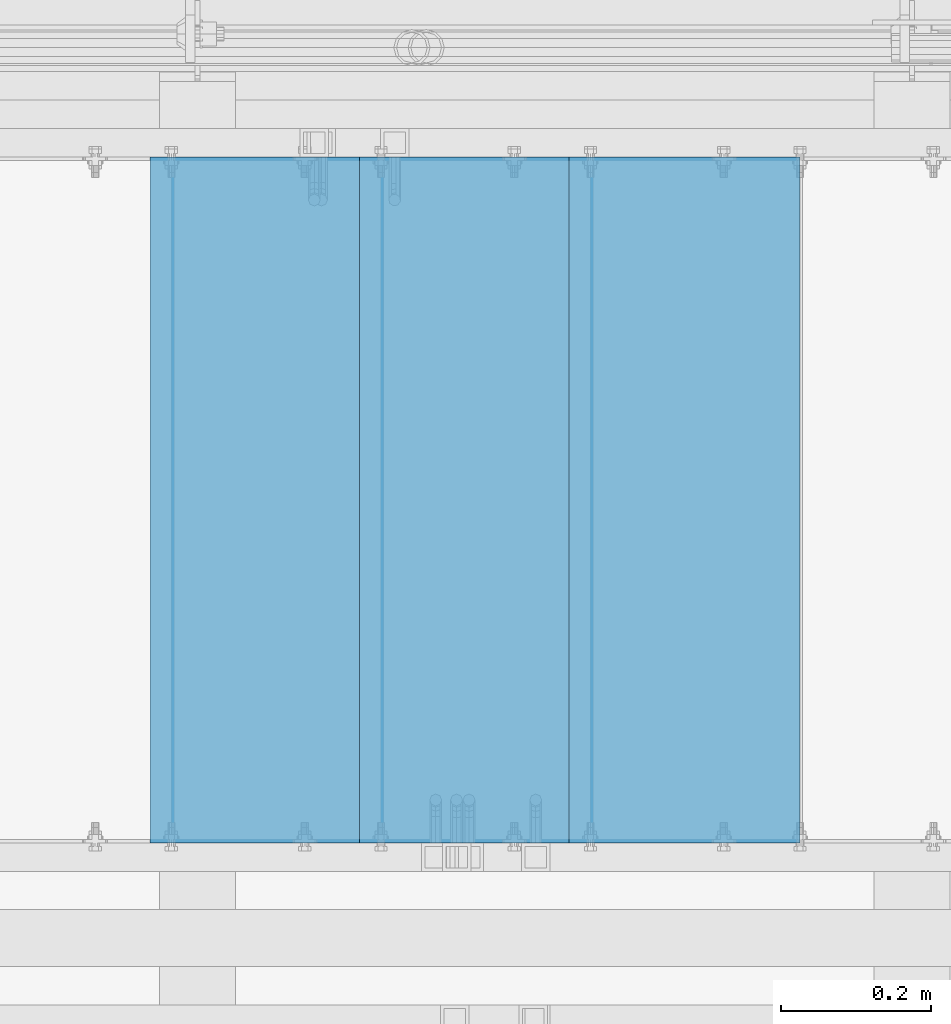
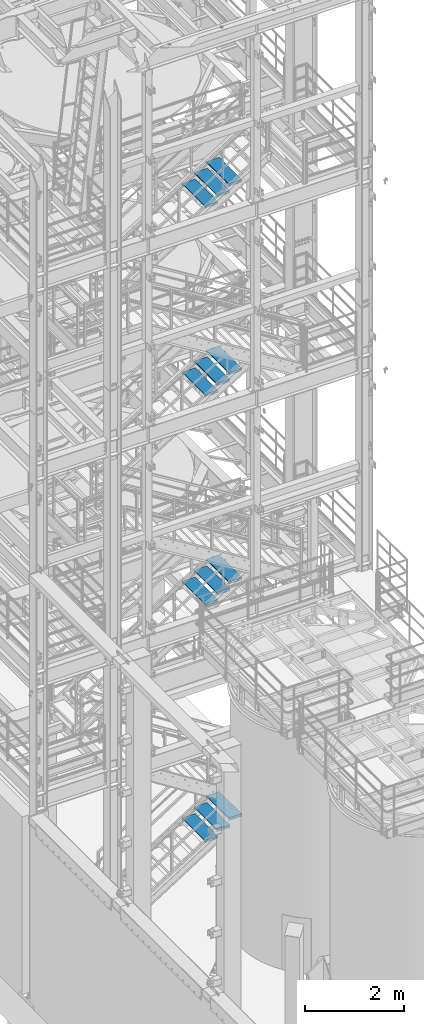
# One storey, part 1189 of 1876: 12 beams, 4 elements without a shape of their own.
"""IFC2X3 building model written with IfcOpenShell, lengths in millimetres."""

from ifc_helpers import new_model, si_unit, frame, origin_with_axes, place, context, subcontext, project, spatial, faceted_brep, material, type_object, element, aggregate, save


model = new_model("IFC2X3")

# Units and contexts
model_context = context("Model", 3, precision=1e-05, world=origin_with_axes())
body_context = subcontext(model_context, "Body", "Model", "MODEL_VIEW")
ifc_project = project(units=[si_unit("LENGTHUNIT", "METRE", prefix="MILLI"), si_unit("AREAUNIT", "SQUARE_METRE"), si_unit("VOLUMEUNIT", "CUBIC_METRE"), si_unit("MASSUNIT", "GRAM", prefix="KILO"), si_unit("TIMEUNIT", "SECOND"), si_unit("PLANEANGLEUNIT", "RADIAN"), si_unit("SOLIDANGLEUNIT", "STERADIAN"), si_unit("THERMODYNAMICTEMPERATUREUNIT", "DEGREE_CELSIUS"), si_unit("LUMINOUSINTENSITYUNIT", "LUMEN")], contexts=[model_context])

# Site, building, storey
site_placement = place(None, origin_with_axes())
site = spatial("IfcSite", under=ifc_project, at=site_placement, CompositionType="ELEMENT")
building_placement = place(site_placement, origin_with_axes())
building = spatial("IfcBuilding", under=site, at=building_placement, Name="Undefined", CompositionType="ELEMENT")
storey_placement = place(building_placement, origin_with_axes())
storey = spatial("IfcBuildingStorey", under=building, at=storey_placement, Name="Undefined", CompositionType="ELEMENT", Elevation=0.0)

# Assembly, beams
assembly_1_placement = place(storey_placement, origin_with_axes())
assembly_1 = element("IfcElementAssembly", 1, at=assembly_1_placement, inside=storey, Name="STRINGER", AssemblyPlace="NOTDEFINED", PredefinedType="RIGID_FRAME")
ifc_material = material(Name="STEEL/A36")
beam_type = type_object("IfcBeamType", PredefinedType="NOTDEFINED")
beam_1_placement = place(assembly_1_placement, frame((5411.78749667753, -5710.23700114275, 17463.9111119387), z_axis=(-1.0, 0.0, 0.0), x_axis=(0.0, 1.0, 0.0)))
beam_1 = element("IfcBeam", 2, at=beam_1_placement, type_object=beam_type, material=ifc_material, Name="TREAD", context=body_context, shape_type="Brep", body=[
    faceted_brep([(-7.45785655453801e-11, 53.9750000000167, -153.9875), (-7.45785655453801e-11, 53.9750000000167, 153.987506103515), (0.0, 9.52499999999964, 153.9875), (-7.45785655453801e-11, 9.52499999999964, -153.9875), (-4.76300000007541, 53.9750000000167, -153.9875), (-4.76300000007541, 53.9750000000167, 153.987506103515), (-4.76300000007541, -9.52499999998327, -153.9875), (-4.76300000007541, -9.52500000019427, 153.987536621094), (909.637000008669, -9.52500000248983, 153.987506103515), (909.637000008669, 53.9749999975102, 153.987506103515), (904.87400000867, 53.9749999975102, 153.987506103515), (904.87400000867, 9.52499999999964, 153.987506103515), (-7.45785655453801e-11, -9.52500000019427, 153.987536621094), (904.87400000867, -9.52500000248983, 153.987506103515), (904.87400000867, 9.52499999999964, -153.9875), (909.637000008669, -9.52500000248983, -153.9875), (909.637000008669, 53.9749999975102, -153.9875), (904.87400000867, 53.9749999975102, -153.9875)], [[[0, 1, 2, 3]], [[1, 0, 4, 5]], [[5, 4, 6, 7]], [[8, 9, 10, 11, 2, 1, 5, 7, 12, 13]], [[14, 3, 2, 11]], [[15, 8, 13, 12, 7, 6]], [[9, 16, 17, 10]], [[16, 9, 8, 15]], [[16, 15, 6, 4, 0, 3, 14, 17]], [[10, 17, 14, 11]]]),
])
beam_2_placement = place(assembly_1_placement, frame((5132.3874964318, -5710.23700114328, 17290.8148155306), z_axis=(-1.0, 0.0, 0.0), x_axis=(0.0, 1.0, 0.0)))
beam_2 = element("IfcBeam", 3, at=beam_2_placement, type_object=beam_type, material=ifc_material, Name="TREAD", context=body_context, shape_type="Brep", body=[
    faceted_brep([(-7.45785655453801e-11, 53.9750000000167, -153.9875), (-7.45785655453801e-11, 53.9750000000167, 153.987506103515), (0.0, 9.52499999999964, 153.9875), (-7.45785655453801e-11, 9.52499999999964, -153.9875), (-4.76300000007541, 53.9750000000167, -153.9875), (-4.76300000007541, 53.9750000000167, 153.987506103515), (-4.76300000007541, -9.52499999998327, -153.9875), (-4.76300000007541, -9.52500000019427, 153.987536621094), (909.637000008669, -9.52500000248983, 153.987506103515), (909.637000008669, 53.9749999975102, 153.987506103515), (904.87400000867, 53.9749999975102, 153.987506103515), (904.87400000867, 9.52499999999964, 153.987506103515), (-7.45785655453801e-11, -9.52500000019427, 153.987536621094), (904.87400000867, -9.52500000248983, 153.987506103515), (904.87400000867, 9.52499999999964, -153.9875), (909.637000008669, -9.52500000248983, -153.9875), (909.637000008669, 53.9749999975102, -153.9875), (904.87400000867, 53.9749999975102, -153.9875)], [[[0, 1, 2, 3]], [[1, 0, 4, 5]], [[5, 4, 6, 7]], [[8, 9, 10, 11, 2, 1, 5, 7, 12, 13]], [[14, 3, 2, 11]], [[15, 8, 13, 12, 7, 6]], [[9, 16, 17, 10]], [[16, 9, 8, 15]], [[16, 15, 6, 4, 0, 3, 14, 17]], [[10, 17, 14, 11]]]),
])
beam_3_placement = place(assembly_1_placement, frame((4852.98749618608, -5710.23700114381, 17117.7185191224), z_axis=(-1.0, 0.0, 0.0), x_axis=(0.0, 1.0, 0.0)))
beam_3 = element("IfcBeam", 4, at=beam_3_placement, type_object=beam_type, material=ifc_material, Name="TREAD", context=body_context, shape_type="Brep", body=[
    faceted_brep([(-7.45785655453801e-11, 53.9750000000167, -153.9875), (-7.45785655453801e-11, 53.9750000000167, 153.987506103515), (0.0, 9.52499999999964, 153.9875), (-7.45785655453801e-11, 9.52499999999964, -153.9875), (-4.76300000007541, 53.9750000000167, -153.9875), (-4.76300000007541, 53.9750000000167, 153.987506103515), (-4.76300000007541, -9.52499999998327, -153.9875), (-4.76300000007541, -9.52500000019427, 153.987536621094), (909.637000008669, -9.52500000248983, 153.987506103515), (909.637000008669, 53.9749999975102, 153.987506103515), (904.87400000867, 53.9749999975102, 153.987506103515), (904.87400000867, 9.52499999999964, 153.987506103515), (-7.45785655453801e-11, -9.52500000019427, 153.987536621094), (904.87400000867, -9.52500000248983, 153.987506103515), (904.87400000867, 9.52499999999964, -153.9875), (909.637000008669, -9.52500000248983, -153.9875), (909.637000008669, 53.9749999975102, -153.9875), (904.87400000867, 53.9749999975102, -153.9875)], [[[0, 1, 2, 3]], [[1, 0, 4, 5]], [[5, 4, 6, 7]], [[8, 9, 10, 11, 2, 1, 5, 7, 12, 13]], [[14, 3, 2, 11]], [[15, 8, 13, 12, 7, 6]], [[9, 16, 17, 10]], [[16, 9, 8, 15]], [[16, 15, 6, 4, 0, 3, 14, 17]], [[10, 17, 14, 11]]]),
])
aggregate(assembly_1, [beam_1, beam_2, beam_3])

assembly_2_placement = place(storey_placement, origin_with_axes())
assembly_2 = element("IfcElementAssembly", 5, at=assembly_2_placement, inside=storey, Name="STRINGER", AssemblyPlace="NOTDEFINED", PredefinedType="RIGID_FRAME")
beam_4_placement = place(assembly_2_placement, frame((5411.78750027259, -5710.23700114556, 12793.9800000199), z_axis=(-1.0, 0.0, 0.0), x_axis=(0.0, 1.0, 0.0)))
beam_4 = element("IfcBeam", 6, at=beam_4_placement, type_object=beam_type, material=ifc_material, Name="TREAD", context=body_context, shape_type="Brep", body=[
    faceted_brep([(-7.45785655453801e-11, 53.9750000000167, -153.9875), (-7.45785655453801e-11, 53.9750000000167, 153.987506103515), (0.0, 9.52499999999964, 153.9875), (-7.45785655453801e-11, 9.52499999999964, -153.9875), (-4.76300000007541, 53.9750000000167, -153.9875), (-4.76300000007541, 53.9750000000167, 153.987506103515), (-4.76300000007541, -9.52499999998327, -153.9875), (-4.76300000007541, -9.52500000019427, 153.987536621094), (909.637000008669, -9.52500000248983, 153.987506103515), (909.637000008669, 53.9749999975102, 153.987506103515), (904.87400000867, 53.9749999975102, 153.987506103515), (904.87400000867, 9.52499999999964, 153.987506103515), (-7.45785655453801e-11, -9.52500000019427, 153.987536621094), (904.87400000867, -9.52500000248983, 153.987506103515), (904.87400000867, 9.52499999999964, -153.9875), (909.637000008669, -9.52500000248983, -153.9875), (909.637000008669, 53.9749999975102, -153.9875), (904.87400000867, 53.9749999975102, -153.9875)], [[[0, 1, 2, 3]], [[1, 0, 4, 5]], [[5, 4, 6, 7]], [[8, 9, 10, 11, 2, 1, 5, 7, 12, 13]], [[14, 3, 2, 11]], [[15, 8, 13, 12, 7, 6]], [[9, 16, 17, 10]], [[16, 9, 8, 15]], [[16, 15, 6, 4, 0, 3, 14, 17]], [[10, 17, 14, 11]]]),
])
beam_5_placement = place(assembly_2_placement, frame((5132.38750036631, -5710.23700114556, 12622.1066666865), z_axis=(-1.0, 0.0, 0.0), x_axis=(0.0, 1.0, 0.0)))
beam_5 = element("IfcBeam", 7, at=beam_5_placement, type_object=beam_type, material=ifc_material, Name="TREAD", context=body_context, shape_type="Brep", body=[
    faceted_brep([(-7.45785655453801e-11, 53.9750000000167, -153.9875), (-7.45785655453801e-11, 53.9750000000167, 153.987506103515), (0.0, 9.52499999999964, 153.9875), (-7.45785655453801e-11, 9.52499999999964, -153.9875), (-4.76300000007541, 53.9750000000167, -153.9875), (-4.76300000007541, 53.9750000000167, 153.987506103515), (-4.76300000007541, -9.52499999998327, -153.9875), (-4.76300000007541, -9.52500000019427, 153.987536621094), (909.637000008669, -9.52500000248983, 153.987506103515), (909.637000008669, 53.9749999975102, 153.987506103515), (904.87400000867, 53.9749999975102, 153.987506103515), (904.87400000867, 9.52499999999964, 153.987506103515), (-7.45785655453801e-11, -9.52500000019427, 153.987536621094), (904.87400000867, -9.52500000248983, 153.987506103515), (904.87400000867, 9.52499999999964, -153.9875), (909.637000008669, -9.52500000248983, -153.9875), (909.637000008669, 53.9749999975102, -153.9875), (904.87400000867, 53.9749999975102, -153.9875)], [[[0, 1, 2, 3]], [[1, 0, 4, 5]], [[5, 4, 6, 7]], [[8, 9, 10, 11, 2, 1, 5, 7, 12, 13]], [[14, 3, 2, 11]], [[15, 8, 13, 12, 7, 6]], [[9, 16, 17, 10]], [[16, 9, 8, 15]], [[16, 15, 6, 4, 0, 3, 14, 17]], [[10, 17, 14, 11]]]),
])
beam_6_placement = place(assembly_2_placement, frame((4852.98750046003, -5710.23700114556, 12450.2333333532), z_axis=(-1.0, 0.0, 0.0), x_axis=(0.0, 1.0, 0.0)))
beam_6 = element("IfcBeam", 8, at=beam_6_placement, type_object=beam_type, material=ifc_material, Name="TREAD", context=body_context, shape_type="Brep", body=[
    faceted_brep([(-7.45785655453801e-11, 53.9750000000167, -153.9875), (-7.45785655453801e-11, 53.9750000000167, 153.987506103515), (0.0, 9.52499999999964, 153.9875), (-7.45785655453801e-11, 9.52499999999964, -153.9875), (-4.76300000007541, 53.9750000000167, -153.9875), (-4.76300000007541, 53.9750000000167, 153.987506103515), (-4.76300000007541, -9.52499999998327, -153.9875), (-4.76300000007541, -9.52500000019427, 153.987536621094), (909.637000008669, -9.52500000248983, 153.987506103515), (909.637000008669, 53.9749999975102, 153.987506103515), (904.87400000867, 53.9749999975102, 153.987506103515), (904.87400000867, 9.52499999999964, 153.987506103515), (-7.45785655453801e-11, -9.52500000019427, 153.987536621094), (904.87400000867, -9.52500000248983, 153.987506103515), (904.87400000867, 9.52499999999964, -153.9875), (909.637000008669, -9.52500000248983, -153.9875), (909.637000008669, 53.9749999975102, -153.9875), (904.87400000867, 53.9749999975102, -153.9875)], [[[0, 1, 2, 3]], [[1, 0, 4, 5]], [[5, 4, 6, 7]], [[8, 9, 10, 11, 2, 1, 5, 7, 12, 13]], [[14, 3, 2, 11]], [[15, 8, 13, 12, 7, 6]], [[9, 16, 17, 10]], [[16, 9, 8, 15]], [[16, 15, 6, 4, 0, 3, 14, 17]], [[10, 17, 14, 11]]]),
])
aggregate(assembly_2, [beam_4, beam_5, beam_6])

assembly_3_placement = place(storey_placement, origin_with_axes())
assembly_3 = element("IfcElementAssembly", 9, at=assembly_3_placement, inside=storey, Name="STRINGER", AssemblyPlace="NOTDEFINED", PredefinedType="RIGID_FRAME")
beam_7_placement = place(assembly_3_placement, frame((5411.78749524543, -5710.23700113625, 7619.99999886843), z_axis=(-1.0, 0.0, 0.0), x_axis=(0.0, 1.0, 0.0)))
beam_7 = element("IfcBeam", 10, at=beam_7_placement, type_object=beam_type, material=ifc_material, Name="TREAD", context=body_context, shape_type="Brep", body=[
    faceted_brep([(-7.45785655453801e-11, 53.9750000000167, -153.9875), (-7.45785655453801e-11, 53.9750000000167, 153.987506103515), (0.0, 9.52499999999964, 153.9875), (-7.45785655453801e-11, 9.52499999999964, -153.9875), (-4.76300000007541, 53.9750000000167, -153.9875), (-4.76300000007541, 53.9750000000167, 153.987506103515), (-4.76300000007541, -9.52499999998327, -153.9875), (-4.76300000007541, -9.52500000019427, 153.987536621094), (909.637000008669, -9.52500000248983, 153.987506103515), (909.637000008669, 53.9749999975102, 153.987506103515), (904.87400000867, 53.9749999975102, 153.987506103515), (904.87400000867, 9.52499999999964, 153.987506103515), (-7.45785655453801e-11, -9.52500000019427, 153.987536621094), (904.87400000867, -9.52500000248983, 153.987506103515), (904.87400000867, 9.52499999999964, -153.9875), (909.637000008669, -9.52500000248983, -153.9875), (909.637000008669, 53.9749999975102, -153.9875), (904.87400000867, 53.9749999975102, -153.9875)], [[[0, 1, 2, 3]], [[1, 0, 4, 5]], [[5, 4, 6, 7]], [[8, 9, 10, 11, 2, 1, 5, 7, 12, 13]], [[14, 3, 2, 11]], [[15, 8, 13, 12, 7, 6]], [[9, 16, 17, 10]], [[16, 9, 8, 15]], [[16, 15, 6, 4, 0, 3, 14, 17]], [[10, 17, 14, 11]]]),
])
beam_8_placement = place(assembly_3_placement, frame((5132.38749563552, -5710.23700113625, 7442.1999989492), z_axis=(-1.0, 0.0, 0.0), x_axis=(0.0, 1.0, 0.0)))
beam_8 = element("IfcBeam", 11, at=beam_8_placement, type_object=beam_type, material=ifc_material, Name="TREAD", context=body_context, shape_type="Brep", body=[
    faceted_brep([(-7.45785655453801e-11, 53.9750000000167, -153.9875), (-7.45785655453801e-11, 53.9750000000167, 153.987506103515), (0.0, 9.52499999999964, 153.9875), (-7.45785655453801e-11, 9.52499999999964, -153.9875), (-4.76300000007541, 53.9750000000167, -153.9875), (-4.76300000007541, 53.9750000000167, 153.987506103515), (-4.76300000007541, -9.52499999998327, -153.9875), (-4.76300000007541, -9.52500000019427, 153.987536621094), (909.637000008669, -9.52500000248983, 153.987506103515), (909.637000008669, 53.9749999975102, 153.987506103515), (904.87400000867, 53.9749999975102, 153.987506103515), (904.87400000867, 9.52499999999964, 153.987506103515), (-7.45785655453801e-11, -9.52500000019427, 153.987536621094), (904.87400000867, -9.52500000248983, 153.987506103515), (904.87400000867, 9.52499999999964, -153.9875), (909.637000008669, -9.52500000248983, -153.9875), (909.637000008669, 53.9749999975102, -153.9875), (904.87400000867, 53.9749999975102, -153.9875)], [[[0, 1, 2, 3]], [[1, 0, 4, 5]], [[5, 4, 6, 7]], [[8, 9, 10, 11, 2, 1, 5, 7, 12, 13]], [[14, 3, 2, 11]], [[15, 8, 13, 12, 7, 6]], [[9, 16, 17, 10]], [[16, 9, 8, 15]], [[16, 15, 6, 4, 0, 3, 14, 17]], [[10, 17, 14, 11]]]),
])
beam_9_placement = place(assembly_3_placement, frame((4852.98749602562, -5710.23700113625, 7264.39999902997), z_axis=(-1.0, 0.0, 0.0), x_axis=(0.0, 1.0, 0.0)))
beam_9 = element("IfcBeam", 12, at=beam_9_placement, type_object=beam_type, material=ifc_material, Name="TREAD", context=body_context, shape_type="Brep", body=[
    faceted_brep([(-7.45785655453801e-11, 53.9750000000167, -153.9875), (-7.45785655453801e-11, 53.9750000000167, 153.987506103515), (0.0, 9.52499999999964, 153.9875), (-7.45785655453801e-11, 9.52499999999964, -153.9875), (-4.76300000007541, 53.9750000000167, -153.9875), (-4.76300000007541, 53.9750000000167, 153.987506103515), (-4.76300000007541, -9.52499999998327, -153.9875), (-4.76300000007541, -9.52500000019427, 153.987536621094), (909.637000008669, -9.52500000248983, 153.987506103515), (909.637000008669, 53.9749999975102, 153.987506103515), (904.87400000867, 53.9749999975102, 153.987506103515), (904.87400000867, 9.52499999999964, 153.987506103515), (-7.45785655453801e-11, -9.52500000019427, 153.987536621094), (904.87400000867, -9.52500000248983, 153.987506103515), (904.87400000867, 9.52499999999964, -153.9875), (909.637000008669, -9.52500000248983, -153.9875), (909.637000008669, 53.9749999975102, -153.9875), (904.87400000867, 53.9749999975102, -153.9875)], [[[0, 1, 2, 3]], [[1, 0, 4, 5]], [[5, 4, 6, 7]], [[8, 9, 10, 11, 2, 1, 5, 7, 12, 13]], [[14, 3, 2, 11]], [[15, 8, 13, 12, 7, 6]], [[9, 16, 17, 10]], [[16, 9, 8, 15]], [[16, 15, 6, 4, 0, 3, 14, 17]], [[10, 17, 14, 11]]]),
])
aggregate(assembly_3, [beam_7, beam_8, beam_9])

assembly_4_placement = place(storey_placement, origin_with_axes())
assembly_4 = element("IfcElementAssembly", 13, at=assembly_4_placement, inside=storey, Name="STRINGER", AssemblyPlace="NOTDEFINED", PredefinedType="RIGID_FRAME")
beam_10_placement = place(assembly_4_placement, frame((5411.78750060753, -5710.23700121136, 1763.00086163999), z_axis=(-1.0, 0.0, 0.0), x_axis=(0.0, 1.0, 0.0)))
beam_10 = element("IfcBeam", 14, at=beam_10_placement, type_object=beam_type, material=ifc_material, Name="TREAD", context=body_context, shape_type="Brep", body=[
    faceted_brep([(-7.45785655453801e-11, 53.9750000000167, -153.9875), (-7.45785655453801e-11, 53.9750000000167, 153.987506103515), (0.0, 9.52499999999964, 153.9875), (-7.45785655453801e-11, 9.52499999999964, -153.9875), (-4.76300000007541, 53.9750000000167, -153.9875), (-4.76300000007541, 53.9750000000167, 153.987506103515), (-4.76300000007541, -9.52499999998327, -153.9875), (-4.76300000007541, -9.52500000019427, 153.987536621094), (909.637000008669, -9.52500000248983, 153.987506103515), (909.637000008669, 53.9749999975102, 153.987506103515), (904.87400000867, 53.9749999975102, 153.987506103515), (904.87400000867, 9.52499999999964, 153.987506103515), (-7.45785655453801e-11, -9.52500000019427, 153.987536621094), (904.87400000867, -9.52500000248983, 153.987506103515), (904.87400000867, 9.52499999999964, -153.9875), (909.637000008669, -9.52500000248983, -153.9875), (909.637000008669, 53.9749999975102, -153.9875), (904.87400000867, 53.9749999975102, -153.9875)], [[[0, 1, 2, 3]], [[1, 0, 4, 5]], [[5, 4, 6, 7]], [[8, 9, 10, 11, 2, 1, 5, 7, 12, 13]], [[14, 3, 2, 11]], [[15, 8, 13, 12, 7, 6]], [[9, 16, 17, 10]], [[16, 9, 8, 15]], [[16, 15, 6, 4, 0, 3, 14, 17]], [[10, 17, 14, 11]]]),
])
beam_11_placement = place(assembly_4_placement, frame((5132.38750058036, -5710.23700121136, 1585.74827547592), z_axis=(-1.0, 0.0, 0.0), x_axis=(0.0, 1.0, 0.0)))
beam_11 = element("IfcBeam", 15, at=beam_11_placement, type_object=beam_type, material=ifc_material, Name="TREAD", context=body_context, shape_type="Brep", body=[
    faceted_brep([(-7.45785655453801e-11, 53.9750000000167, -153.9875), (-7.45785655453801e-11, 53.9750000000167, 153.987506103515), (0.0, 9.52499999999964, 153.9875), (-7.45785655453801e-11, 9.52499999999964, -153.9875), (-4.76300000007541, 53.9750000000167, -153.9875), (-4.76300000007541, 53.9750000000167, 153.987506103515), (-4.76300000007541, -9.52499999998327, -153.9875), (-4.76300000007541, -9.52500000019427, 153.987536621094), (909.637000008669, -9.52500000248983, 153.987506103515), (909.637000008669, 53.9749999975102, 153.987506103515), (904.87400000867, 53.9749999975102, 153.987506103515), (904.87400000867, 9.52499999999964, 153.987506103515), (-7.45785655453801e-11, -9.52500000019427, 153.987536621094), (904.87400000867, -9.52500000248983, 153.987506103515), (904.87400000867, 9.52499999999964, -153.9875), (909.637000008669, -9.52500000248983, -153.9875), (909.637000008669, 53.9749999975102, -153.9875), (904.87400000867, 53.9749999975102, -153.9875)], [[[0, 1, 2, 3]], [[1, 0, 4, 5]], [[5, 4, 6, 7]], [[8, 9, 10, 11, 2, 1, 5, 7, 12, 13]], [[14, 3, 2, 11]], [[15, 8, 13, 12, 7, 6]], [[9, 16, 17, 10]], [[16, 9, 8, 15]], [[16, 15, 6, 4, 0, 3, 14, 17]], [[10, 17, 14, 11]]]),
])
beam_12_placement = place(assembly_4_placement, frame((4852.98750055319, -5710.23700121136, 1408.49568931185), z_axis=(-1.0, 0.0, 0.0), x_axis=(0.0, 1.0, 0.0)))
beam_12 = element("IfcBeam", 16, at=beam_12_placement, type_object=beam_type, material=ifc_material, Name="TREAD", context=body_context, shape_type="Brep", body=[
    faceted_brep([(-7.45785655453801e-11, 53.9750000000167, -153.9875), (-7.45785655453801e-11, 53.9750000000167, 153.987506103515), (0.0, 9.52499999999964, 153.9875), (-7.45785655453801e-11, 9.52499999999964, -153.9875), (-4.76300000007541, 53.9750000000167, -153.9875), (-4.76300000007541, 53.9750000000167, 153.987506103515), (-4.76300000007541, -9.52499999998327, -153.9875), (-4.76300000007541, -9.52500000019427, 153.987536621094), (909.637000008669, -9.52500000248983, 153.987506103515), (909.637000008669, 53.9749999975102, 153.987506103515), (904.87400000867, 53.9749999975102, 153.987506103515), (904.87400000867, 9.52499999999964, 153.987506103515), (-7.45785655453801e-11, -9.52500000019427, 153.987536621094), (904.87400000867, -9.52500000248983, 153.987506103515), (904.87400000867, 9.52499999999964, -153.9875), (909.637000008669, -9.52500000248983, -153.9875), (909.637000008669, 53.9749999975102, -153.9875), (904.87400000867, 53.9749999975102, -153.9875)], [[[0, 1, 2, 3]], [[1, 0, 4, 5]], [[5, 4, 6, 7]], [[8, 9, 10, 11, 2, 1, 5, 7, 12, 13]], [[14, 3, 2, 11]], [[15, 8, 13, 12, 7, 6]], [[9, 16, 17, 10]], [[16, 9, 8, 15]], [[16, 15, 6, 4, 0, 3, 14, 17]], [[10, 17, 14, 11]]]),
])
aggregate(assembly_4, [beam_10, beam_11, beam_12])

save(model, "model.ifc")
